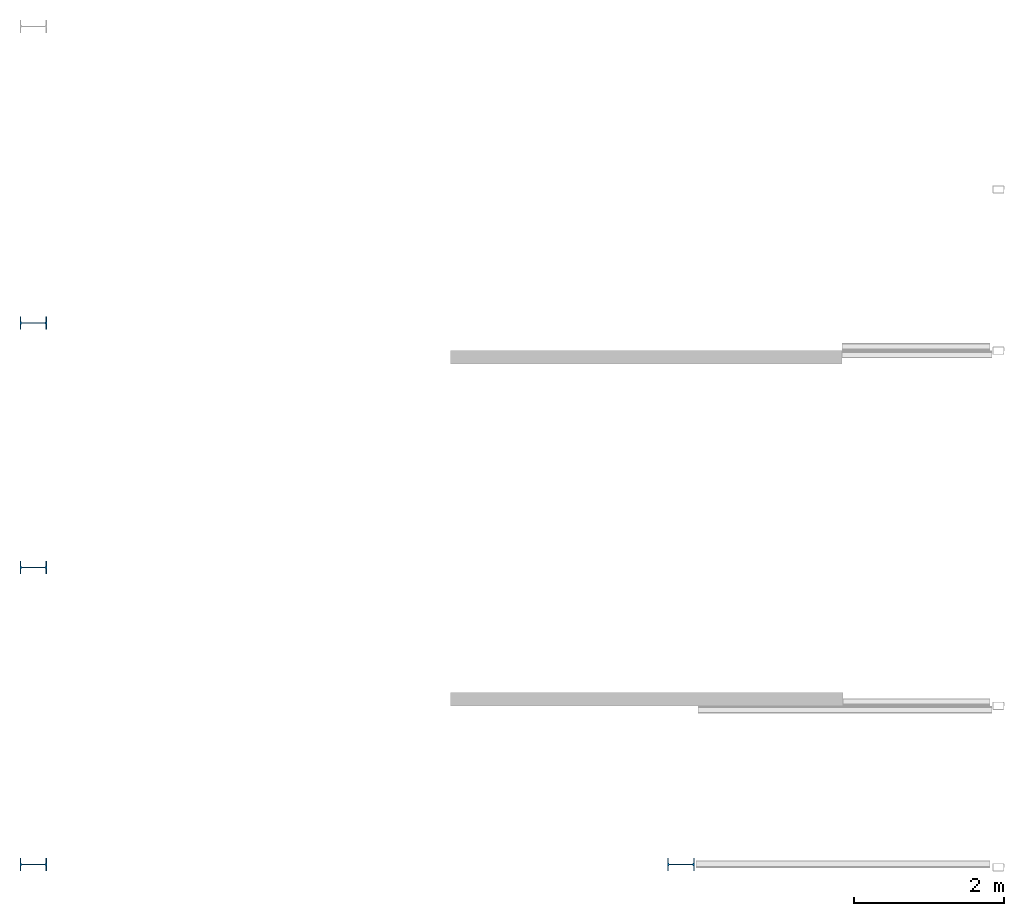
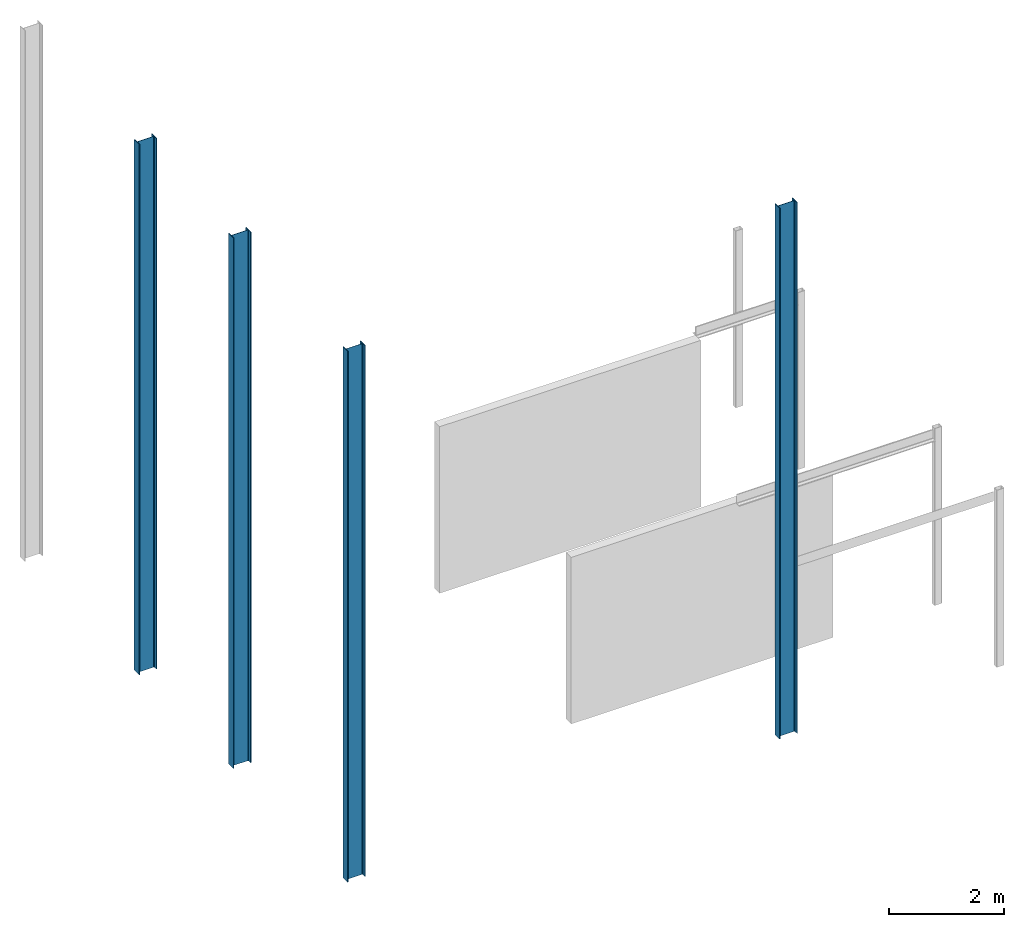
# One storey, part 1 of 4: 4 columns.
"""IFC2X3 building model written with IfcOpenShell, lengths in millimetres."""

from ifc_helpers import new_model, entity, si_unit, converted_unit, frame, frame_2d, origin, place, context, project, spatial, polyline, circle_curve, parameter, trimmed, segment, composite_curve, outline, extrude, source, transform, mapped, material, type_object, type_shapes, element, save


model = new_model("IFC2X3")

# Units and contexts
model_context = context("Model", 3, precision=1e-06, world=origin())
plan_context = context("Plan", 3, precision=1e-06, world=origin())
ifc_project = project(units=[si_unit("LENGTHUNIT", "METRE", prefix="MILLI"), si_unit("AREAUNIT", "SQUARE_METRE", prefix="MILLI"), si_unit("VOLUMEUNIT", "CUBIC_METRE", prefix="MILLI"), converted_unit("PLANEANGLEUNIT", "DEGREE", entity("IfcRatioMeasure", 0.01745329251994328), si_unit("PLANEANGLEUNIT", "RADIAN"), dimensions=[0, 0, 0, 0, 0, 0, 0]), si_unit("TIMEUNIT", "SECOND")], contexts=[model_context, plan_context])

# Site, building, storey
site_placement = place(None, origin())
site = spatial("IfcSite", under=ifc_project, at=site_placement, CompositionType="ELEMENT")
building_placement = place(None, origin())
building = spatial("IfcBuilding", under=site, at=building_placement, CompositionType="ELEMENT")
storey_placement = place(building_placement, origin())
storey = spatial("IfcBuildingStorey", under=building, at=storey_placement, Name="Level 1", CompositionType="ELEMENT", Elevation=0.0)

# Columns
ifc_material = material(Name="Metal - Steel - 250 MPa")
column_type = type_object("IfcColumnType", Name="IPE360", PredefinedType="COLUMN")
shared_shape = source(origin(), model_context, "Body", "SweptSolid", [
    extrude(outline(composite_curve([segment(polyline([(-85.0, -180.0), (85.0, -180.0)]), True, "CONTINUOUS"), segment(polyline([(85.0, -180.0), (85.0, -167.3)]), True, "CONTINUOUS"), segment(polyline([(85.0, -167.3), (22.0, -167.3)]), True, "CONTINUOUS"), segment(trimmed(circle_curve(frame_2d((22.0, -149.3), x_axis=(-1.0, 0.0)), 18.0), [parameter(3.562221243239142e-13)], [parameter(90.00000000000044)], True, "PARAMETER"), False, "CONTINUOUS"), segment(polyline([(4.0, -149.3), (4.0, 149.3)]), True, "CONTINUOUS"), segment(trimmed(circle_curve(frame_2d((22.0, 149.3), x_axis=(-1.0, 0.0)), 18.0), [parameter(270.0000000000003)], [parameter(3.562221243239142e-13)], True, "PARAMETER"), False, "CONTINUOUS"), segment(polyline([(22.0, 167.3), (85.0, 167.3)]), True, "CONTINUOUS"), segment(polyline([(85.0, 167.3), (85.0, 180.0)]), True, "CONTINUOUS"), segment(polyline([(85.0, 180.0), (-85.0, 180.0)]), True, "CONTINUOUS"), segment(polyline([(-85.0, 180.0), (-85.0, 167.3)]), True, "CONTINUOUS"), segment(polyline([(-85.0, 167.3), (-22.0, 167.3)]), True, "CONTINUOUS"), segment(trimmed(circle_curve(frame_2d((-22.0, 149.3), x_axis=(-1.0, 0.0)), 18.0), [parameter(180.0)], [parameter(270.0000000000001)], True, "PARAMETER"), False, "CONTINUOUS"), segment(polyline([(-4.0, 149.3), (-4.0, -149.3)]), True, "CONTINUOUS"), segment(trimmed(circle_curve(frame_2d((-22.0, -149.3), x_axis=(-1.0, 0.0)), 18.0), [parameter(90.00000000000044)], [parameter(180.0000000000002)], True, "PARAMETER"), False, "CONTINUOUS"), segment(polyline([(-22.0, -167.3), (-85.0, -167.3)]), True, "CONTINUOUS"), segment(polyline([(-85.0, -167.3), (-85.0, -180.0)]), True, "CONTINUOUS")], self_intersect=False)), frame((0.0, 0.0, 0.0), z_axis=(0.0, 0.0, 1.0), x_axis=(-1.0, 0.0, 0.0)), (0.0, 0.0, 1.0), 11250.0),
])
type_shapes(column_type, [shared_shape])
for number, where, z_axis, x_axis, name in (
    (1, (-24822.54977824739, 7431.347281587448, 0.0), (0.0, 0.0, 1.0), (0.0, 1.0, 0.0), "IPE-Column:IPE360:IPE360"),
    (2, (-24822.54977824739, 4161.098768151625, 0.0), (0.0, 0.0, 1.0), (0.0, 1.0, 0.0), "IPE-Column:IPE360:IPE360"),
    (3, (-24822.54977824739, 189.0987681516007, 0.0), (0.0, 0.0, 1.0), (0.0, 1.0, 0.0), "IPE-Column:IPE360:IPE360"),
    (4, (-16162.18323242539, 189.0987681516007, 0.0), (0.0, 0.0, 1.0), (0.0, 1.0, 0.0), "IPE-Column:IPE360:IPE360"),
):
    element("IfcColumn", number, at=place(storey_placement, frame(where, z_axis=z_axis, x_axis=x_axis)), inside=storey, type_object=column_type, material=ifc_material, Name=name, ObjectType="IPE360", context=model_context, shape_type="MappedRepresentation", body=[
        mapped(shared_shape, transform((0.0, 0.0, 0.0), scale=1.0)),
    ])

save(model, "model.ifc")
